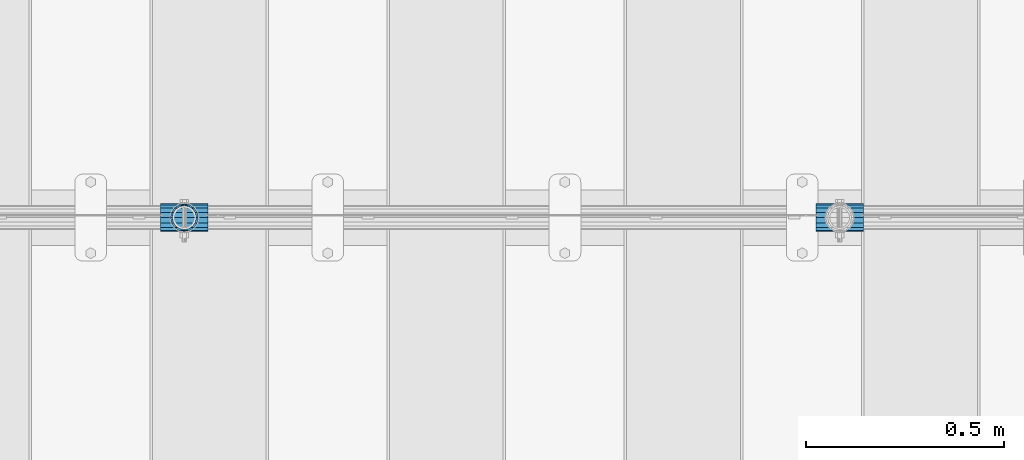
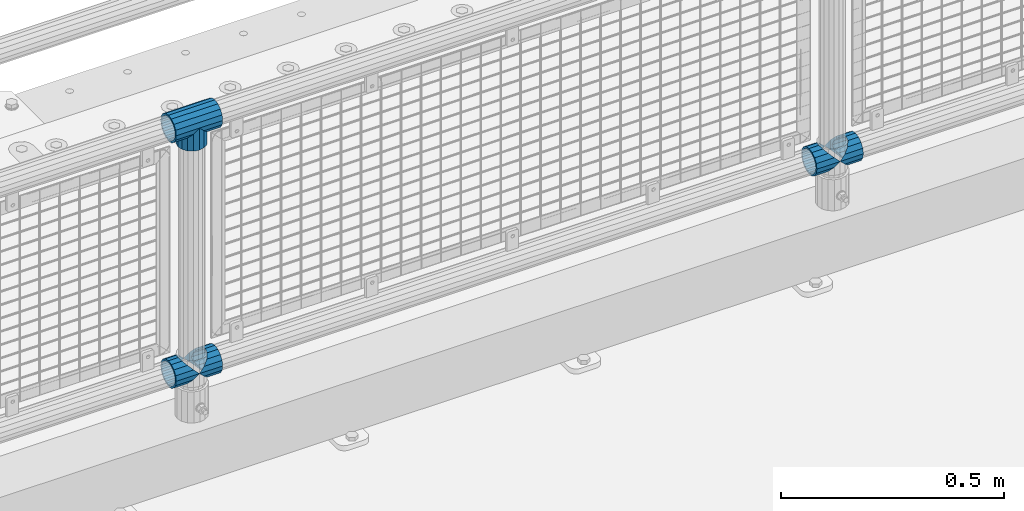
# One storey, part 114 of 193: 6 beams.
"""IFC2X3 building model written with IfcOpenShell, lengths in millimetres."""

from ifc_helpers import new_model, si_unit, frame, origin_with_axes, place, context, subcontext, project, spatial, faceted_brep, material, type_object, element, save


model = new_model("IFC2X3")

# Units and contexts
model_context = context("Model", 3, precision=1e-05, world=origin_with_axes())
body_context = subcontext(model_context, "Body", "Model", "MODEL_VIEW")
ifc_project = project(units=[si_unit("LENGTHUNIT", "METRE", prefix="MILLI"), si_unit("AREAUNIT", "SQUARE_METRE"), si_unit("VOLUMEUNIT", "CUBIC_METRE"), si_unit("MASSUNIT", "GRAM", prefix="KILO"), si_unit("TIMEUNIT", "SECOND"), si_unit("PLANEANGLEUNIT", "RADIAN"), si_unit("SOLIDANGLEUNIT", "STERADIAN"), si_unit("THERMODYNAMICTEMPERATUREUNIT", "DEGREE_CELSIUS"), si_unit("LUMINOUSINTENSITYUNIT", "LUMEN")], contexts=[model_context])

# Site, building, storey
site_placement = place(None, origin_with_axes())
site = spatial("IfcSite", under=ifc_project, at=site_placement, CompositionType="ELEMENT")
building_placement = place(site_placement, origin_with_axes())
building = spatial("IfcBuilding", under=site, at=building_placement, Name="Standard", CompositionType="ELEMENT")
storey_placement = place(building_placement, origin_with_axes())
storey = spatial("IfcBuildingStorey", under=building, at=storey_placement, Name="Undefined", CompositionType="ELEMENT", Elevation=0.0)

# Beams
ifc_material = material(Name="Misc_Undefined")
beam_type = type_object("IfcBeamType", PredefinedType="NOTDEFINED")
beam_1_placement = place(storey_placement, frame((-36915.15, 28664.5, 298.17), z_axis=(0.0, 1.0, 0.0), x_axis=(1.0, 0.0, 0.0)))
element("IfcBeam", 1, at=beam_1_placement, inside=storey, type_object=beam_type, material=ifc_material, context=body_context, shape_type="Brep", body=[
    faceted_brep([(60.1500000000015, 0.0, -35.1500000000015), (46.6986773523677, 13.4513226476329, -32.4743655677703), (46.6986773523677, -13.4513226476329, -32.4743655677703), (33.0273231408864, 21.4606908090117, 21.46069080901), (27.6756344322312, 26.8123795176734, 13.4513226476338), (27.6756344322312, 32.4743655677717, 13.4513226476338), (35.2951966412948, 24.8548033587072, 24.8548033587067), (35.2951966412948, 16.3810424080078, 24.8548033587067), (27.3102561882843, 28.0397438117175, 11.614442172282), (25.0, 30.35, 0.0), (25.0, 35.15, 0.0), (27.6756344322312, 26.8123795176755, -13.4513226476338), (27.6756344322312, 32.4743655677717, -13.4513226476338), (27.3102561882843, 28.0397438117175, -11.614442172282), (35.2951966412948, 16.3810424080013, -24.8548033587067), (35.2951966412948, 24.8548033587072, -24.8548033587067), (33.0273231408974, 21.4606908090117, -21.46069080901), (40.0617968770202, 11.6144421722805, -28.0397438117179), (43.519339601633, 0.0, -30.3499999999985), (40.0617968770202, -11.6144421722805, -28.0397438117179), (35.2951966412948, -16.3810424080013, -24.8548033587067), (35.2951966412948, -24.8548033587072, -24.8548033587067), (33.0273231408974, -21.4606908090117, -21.46069080901), (27.6756344322312, -26.8123795176734, -13.4513226476338), (27.6756344322312, -32.4743655677717, -13.4513226476338), (27.3102561882843, -28.0397438117175, -11.614442172282), (25.0, -30.35, 0.0), (25.0, -35.15, 0.0), (27.3102561882843, -28.0397438117175, 11.614442172282), (27.6756344322312, -26.8123795176755, 13.4513226476338), (27.6756344322312, -32.4743655677717, 13.4513226476338), (33.0273231408864, -21.4606908090117, 21.46069080901), (35.2951966412948, -16.3810424080013, 24.8548033587067), (35.2951966412948, -24.8548033587072, 24.8548033587067), (60.1500000000015, 0.0, 35.1500000000015), (46.6986773523677, -13.4513226476329, 32.4743655677703), (46.6986773523677, 13.4513226476329, 32.4743655677703), (40.0617968770275, -11.6144421722805, 28.0397438117179), (43.5193396016439, 0.0, 30.3499999999985), (40.0617968770275, 11.6144421722805, 28.0397438117179), (0.0, -32.4743655677703, -13.4513226476338), (0.0, -24.8548033587067, -24.8548033587067), (0.0, -13.4513226476338, -32.4743655677703), (0.0, 0.0, -35.1500000000015), (0.0, 13.4513226476338, -32.4743655677703), (0.0, 24.8548033587067, -24.8548033587067), (0.0, 32.4743655677703, -13.4513226476338), (0.0, 35.1500000000015, 0.0), (0.0, 32.4743655677703, 13.4513226476338), (0.0, 24.8548033587067, 24.8548033587067), (0.0, 13.4513226476338, 32.4743655677703), (0.0, 0.0, 35.1500000000015), (0.0, -32.4743655677703, 13.4513226476338), (0.0, -35.1500000000015, 0.0), (0.0, -24.8548033587067, 24.8548033587067), (0.0, -13.4513226476338, 32.4743655677703), (0.0, -28.0397438117179, -11.614442172282), (0.0, -21.46069080901, -21.46069080901), (0.0, -11.614442172282, -28.0397438117179), (0.0, 0.0, -30.3499999999985), (0.0, 11.614442172282, -28.0397438117179), (0.0, 21.46069080901, -21.46069080901), (0.0, 28.0397438117179, -11.614442172282), (0.0, 30.3499999999985, 0.0), (0.0, 28.0397438117179, 11.614442172282), (0.0, 21.46069080901, 21.46069080901), (0.0, 11.614442172282, 28.0397438117179), (0.0, 0.0, 30.3499999999985), (0.0, -11.614442172282, 28.0397438117179), (0.0, -21.46069080901, 21.46069080901), (0.0, -28.0397438117179, 11.614442172282), (0.0, -30.3499999999985, 0.0)], [[[0, 1, 2]], [[3, 4, 5, 6, 7]], [[8, 9, 10, 5, 4]], [[11, 12, 10, 9, 13]], [[14, 15, 12, 11, 16]], [[2, 1, 15, 14, 17, 18, 19, 20, 21]], [[21, 20, 22, 23, 24]], [[24, 23, 25, 26, 27]], [[27, 26, 28, 29, 30]], [[30, 29, 31, 32, 33]], [[34, 35, 36]], [[33, 32, 37, 38, 39, 7, 6, 36, 35]], [[40, 41, 21, 24]], [[41, 42, 2, 21]], [[42, 43, 0, 2]], [[43, 44, 1, 0]], [[44, 45, 15, 1]], [[45, 46, 12, 15]], [[46, 47, 10, 12]], [[47, 48, 5, 10]], [[48, 49, 6, 5]], [[49, 50, 36, 6]], [[50, 51, 34, 36]], [[52, 53, 27, 30]], [[54, 52, 30, 33]], [[55, 54, 33, 35]], [[51, 55, 35, 34]], [[53, 40, 24, 27]], [[52, 54, 55, 51, 50, 49, 48, 47, 46, 45, 44, 43, 42, 41, 40, 53], [56, 57, 58, 59, 60, 61, 62, 63, 64, 65, 66, 67, 68, 69, 70, 71]], [[68, 67, 38, 37]], [[31, 69, 68, 37, 32]], [[28, 70, 69, 31, 29]], [[71, 70, 28, 26]], [[56, 71, 26, 25]], [[57, 56, 25, 23, 22]], [[58, 57, 22, 20, 19]], [[59, 58, 19, 18]], [[60, 59, 18, 17]], [[16, 61, 60, 17, 14]], [[13, 62, 61, 16, 11]], [[63, 62, 13, 9]], [[64, 63, 9, 8]], [[65, 64, 8, 4, 3]], [[66, 65, 3, 7, 39]], [[67, 66, 39, 38]]]),
])
beam_2_placement = place(storey_placement, frame((-36855.0, 28664.5, 298.17), z_axis=(0.0, 1.0, 0.0), x_axis=(1.0, 0.0, 0.0)))
element("IfcBeam", 2, at=beam_2_placement, inside=storey, type_object=beam_type, material=ifc_material, context=body_context, shape_type="Brep", body=[
    faceted_brep([(0.0, 0.0, 35.1500000000015), (13.4513226476338, 13.4513226476329, 32.4743655677703), (13.4513226476338, -13.4513226476329, 32.4743655677703), (24.8548033587067, -16.3810424080013, -24.8548033587067), (24.8548033587067, -24.8548033587072, -24.8548033587067), (32.4743655677703, -32.4743655677717, -13.4513226476338), (32.4743655677703, -26.8123795176754, -13.4513226476338), (27.1226768591114, -21.4606908090117, -21.46069080901), (0.0, 0.0, -35.1500000000015), (13.4513226476338, -13.4513226476329, -32.4743655677703), (13.4513226476338, 13.4513226476329, -32.4743655677703), (20.0882031229849, -11.6144421722805, -28.0397438117179), (16.6306603983721, 0.0, -30.3499999999985), (20.0882031229849, 11.6144421722805, -28.0397438117179), (24.8548033587067, 16.3810424080013, -24.8548033587067), (24.8548033587067, 24.8548033587072, -24.8548033587067), (27.1226768591114, 21.4606908090117, -21.46069080901), (32.4743655677703, 26.8123795176776, -13.4513226476338), (32.4743655677703, 32.4743655677717, -13.4513226476338), (32.8397438117172, 28.0397438117175, -11.614442172282), (35.1500000000015, 30.35, 0.0), (35.1500000000015, 35.15, 0.0), (32.8397438117208, 28.0397438117175, 11.614442172282), (32.4743655677703, 26.8123795176754, 13.4513226476338), (32.4743655677703, 32.4743655677717, 13.4513226476338), (27.1226768591041, 21.4606908090117, 21.46069080901), (24.8548033587067, 16.3810424080078, 24.8548033587067), (24.8548033587067, 24.8548033587072, 24.8548033587067), (20.0882031229849, 11.6144421722805, 28.0397438117179), (16.6306603983685, 0.0, 30.3499999999985), (20.0882031229849, -11.6144421722805, 28.0397438117179), (24.8548033587067, -16.3810424080013, 24.8548033587067), (24.8548033587067, -24.8548033587072, 24.8548033587067), (27.1226768591041, -21.4606908090117, 21.46069080901), (32.4743655677703, -26.8123795176776, 13.4513226476338), (32.4743655677703, -32.4743655677717, 13.4513226476338), (32.8397438117208, -28.0397438117175, 11.614442172282), (35.1500000000015, -30.35, 0.0), (35.1500000000015, -35.15, 0.0), (32.8397438117172, -28.0397438117175, -11.614442172282), (60.1500000000015, -24.8548033587072, -24.8548033587067), (60.1500000000015, -32.4743655677717, -13.4513226476338), (60.1500000000015, -13.4513226476329, -32.4743655677703), (60.1500000000015, 0.0, -35.1500000000015), (60.1500000000015, 13.4513226476329, -32.4743655677703), (60.1500000000015, 24.8548033587072, -24.8548033587067), (60.1500000000015, 32.4743655677717, -13.4513226476338), (60.1500000000015, 35.15, 0.0), (60.1500000000015, 32.4743655677717, 13.4513226476338), (60.1500000000015, 24.8548033587072, 24.8548033587067), (60.1500000000015, 13.4513226476329, 32.4743655677703), (60.1500000000015, 0.0, 35.1500000000015), (60.1500000000015, -13.4513226476329, 32.4743655677703), (60.1500000000015, -24.8548033587072, 24.8548033587067), (60.1500000000015, -32.4743655677717, 13.4513226476338), (60.1500000000015, -35.15, 0.0), (60.1500000000015, -21.4606908090117, 21.46069080901), (60.1500000000015, -11.6144421722805, 28.0397438117179), (60.1500000000015, 0.0, 30.3499999999985), (60.1500000000015, 11.6144421722805, 28.0397438117179), (60.1500000000015, 21.4606908090117, 21.46069080901), (60.1500000000015, 28.0397438117175, 11.614442172282), (60.1500000000015, 30.35, 0.0), (60.1500000000015, 28.0397438117175, -11.614442172282), (60.1500000000015, 21.4606908090117, -21.46069080901), (60.1500000000015, 11.6144421722805, -28.0397438117179), (60.1500000000015, 0.0, -30.3499999999985), (60.1500000000015, -11.6144421722805, -28.0397438117179), (60.1500000000015, -21.4606908090117, -21.46069080901), (60.1500000000015, -28.0397438117175, -11.614442172282), (60.1500000000015, -30.35, 0.0), (60.1500000000015, -28.0397438117175, 11.614442172282)], [[[0, 1, 2]], [[3, 4, 5, 6, 7]], [[8, 9, 10]], [[10, 9, 4, 3, 11, 12, 13, 14, 15]], [[15, 14, 16, 17, 18]], [[18, 17, 19, 20, 21]], [[21, 20, 22, 23, 24]], [[24, 23, 25, 26, 27]], [[27, 26, 28, 29, 30, 31, 32, 2, 1]], [[33, 34, 35, 32, 31]], [[36, 37, 38, 35, 34]], [[6, 5, 38, 37, 39]], [[40, 41, 5, 4]], [[42, 40, 4, 9]], [[43, 42, 9, 8]], [[44, 43, 8, 10]], [[45, 44, 10, 15]], [[46, 45, 15, 18]], [[47, 46, 18, 21]], [[48, 47, 21, 24]], [[49, 48, 24, 27]], [[50, 49, 27, 1]], [[51, 50, 1, 0]], [[52, 51, 0, 2]], [[53, 52, 2, 32]], [[54, 53, 32, 35]], [[55, 54, 35, 38]], [[41, 55, 38, 5]], [[40, 42, 43, 44, 45, 46, 47, 48, 49, 50, 51, 52, 53, 54, 55, 41], [56, 57, 58, 59, 60, 61, 62, 63, 64, 65, 66, 67, 68, 69, 70, 71]], [[71, 70, 37, 36]], [[56, 71, 36, 34, 33]], [[57, 56, 33, 31, 30]], [[58, 57, 30, 29]], [[59, 58, 29, 28]], [[25, 60, 59, 28, 26]], [[22, 61, 60, 25, 23]], [[62, 61, 22, 20]], [[63, 62, 20, 19]], [[64, 63, 19, 17, 16]], [[65, 64, 16, 14, 13]], [[66, 65, 13, 12]], [[67, 66, 12, 11]], [[7, 68, 67, 11, 3]], [[39, 69, 68, 7, 6]], [[70, 69, 39, 37]]]),
])
beam_3_placement = place(storey_placement, frame((-38573.15, 28664.5, 298.17), z_axis=(0.0, 1.0, 0.0), x_axis=(1.0, 0.0, 0.0)))
element("IfcBeam", 3, at=beam_3_placement, inside=storey, type_object=beam_type, material=ifc_material, context=body_context, shape_type="Brep", body=[
    faceted_brep([(60.1500000000015, 0.0, -35.1500000000015), (46.6986773523677, 13.4513226476329, -32.4743655677703), (46.6986773523677, -13.4513226476329, -32.4743655677703), (33.0273231408864, 21.4606908090117, 21.46069080901), (27.6756344322312, 26.8123795176734, 13.4513226476338), (27.6756344322312, 32.4743655677717, 13.4513226476338), (35.2951966412948, 24.8548033587072, 24.8548033587067), (35.2951966412948, 16.3810424080078, 24.8548033587067), (27.3102561882843, 28.0397438117175, 11.614442172282), (25.0, 30.35, 0.0), (25.0, 35.15, 0.0), (27.6756344322312, 26.8123795176755, -13.4513226476338), (27.6756344322312, 32.4743655677717, -13.4513226476338), (27.3102561882843, 28.0397438117175, -11.614442172282), (35.2951966412948, 16.3810424080013, -24.8548033587067), (35.2951966412948, 24.8548033587072, -24.8548033587067), (33.0273231408974, 21.4606908090117, -21.46069080901), (40.0617968770202, 11.6144421722805, -28.0397438117179), (43.519339601633, 0.0, -30.3499999999985), (40.0617968770202, -11.6144421722805, -28.0397438117179), (35.2951966412948, -16.3810424080013, -24.8548033587067), (35.2951966412948, -24.8548033587072, -24.8548033587067), (33.0273231408974, -21.4606908090117, -21.46069080901), (27.6756344322312, -26.8123795176734, -13.4513226476338), (27.6756344322312, -32.4743655677717, -13.4513226476338), (27.3102561882843, -28.0397438117175, -11.614442172282), (25.0, -30.35, 0.0), (25.0, -35.15, 0.0), (27.3102561882843, -28.0397438117175, 11.614442172282), (27.6756344322312, -26.8123795176755, 13.4513226476338), (27.6756344322312, -32.4743655677717, 13.4513226476338), (33.0273231408864, -21.4606908090117, 21.46069080901), (35.2951966412948, -16.3810424080013, 24.8548033587067), (35.2951966412948, -24.8548033587072, 24.8548033587067), (60.1500000000015, 0.0, 35.1500000000015), (46.6986773523677, -13.4513226476329, 32.4743655677703), (46.6986773523677, 13.4513226476329, 32.4743655677703), (40.0617968770275, -11.6144421722805, 28.0397438117179), (43.5193396016439, 0.0, 30.3499999999985), (40.0617968770275, 11.6144421722805, 28.0397438117179), (0.0, -32.4743655677703, -13.4513226476338), (0.0, -24.8548033587067, -24.8548033587067), (0.0, -13.4513226476338, -32.4743655677703), (0.0, 0.0, -35.1500000000015), (0.0, 13.4513226476338, -32.4743655677703), (0.0, 24.8548033587067, -24.8548033587067), (0.0, 32.4743655677703, -13.4513226476338), (0.0, 35.1500000000015, 0.0), (0.0, 32.4743655677703, 13.4513226476338), (0.0, 24.8548033587067, 24.8548033587067), (0.0, 13.4513226476338, 32.4743655677703), (0.0, 0.0, 35.1500000000015), (0.0, -32.4743655677703, 13.4513226476338), (0.0, -35.1500000000015, 0.0), (0.0, -24.8548033587067, 24.8548033587067), (0.0, -13.4513226476338, 32.4743655677703), (0.0, -28.0397438117179, -11.614442172282), (0.0, -21.46069080901, -21.46069080901), (0.0, -11.614442172282, -28.0397438117179), (0.0, 0.0, -30.3499999999985), (0.0, 11.614442172282, -28.0397438117179), (0.0, 21.46069080901, -21.46069080901), (0.0, 28.0397438117179, -11.614442172282), (0.0, 30.3499999999985, 0.0), (0.0, 28.0397438117179, 11.614442172282), (0.0, 21.46069080901, 21.46069080901), (0.0, 11.614442172282, 28.0397438117179), (0.0, 0.0, 30.3499999999985), (0.0, -11.614442172282, 28.0397438117179), (0.0, -21.46069080901, 21.46069080901), (0.0, -28.0397438117179, 11.614442172282), (0.0, -30.3499999999985, 0.0)], [[[0, 1, 2]], [[3, 4, 5, 6, 7]], [[8, 9, 10, 5, 4]], [[11, 12, 10, 9, 13]], [[14, 15, 12, 11, 16]], [[2, 1, 15, 14, 17, 18, 19, 20, 21]], [[21, 20, 22, 23, 24]], [[24, 23, 25, 26, 27]], [[27, 26, 28, 29, 30]], [[30, 29, 31, 32, 33]], [[34, 35, 36]], [[33, 32, 37, 38, 39, 7, 6, 36, 35]], [[40, 41, 21, 24]], [[41, 42, 2, 21]], [[42, 43, 0, 2]], [[43, 44, 1, 0]], [[44, 45, 15, 1]], [[45, 46, 12, 15]], [[46, 47, 10, 12]], [[47, 48, 5, 10]], [[48, 49, 6, 5]], [[49, 50, 36, 6]], [[50, 51, 34, 36]], [[52, 53, 27, 30]], [[54, 52, 30, 33]], [[55, 54, 33, 35]], [[51, 55, 35, 34]], [[53, 40, 24, 27]], [[52, 54, 55, 51, 50, 49, 48, 47, 46, 45, 44, 43, 42, 41, 40, 53], [56, 57, 58, 59, 60, 61, 62, 63, 64, 65, 66, 67, 68, 69, 70, 71]], [[68, 67, 38, 37]], [[31, 69, 68, 37, 32]], [[28, 70, 69, 31, 29]], [[71, 70, 28, 26]], [[56, 71, 26, 25]], [[57, 56, 25, 23, 22]], [[58, 57, 22, 20, 19]], [[59, 58, 19, 18]], [[60, 59, 18, 17]], [[16, 61, 60, 17, 14]], [[13, 62, 61, 16, 11]], [[63, 62, 13, 9]], [[64, 63, 9, 8]], [[65, 64, 8, 4, 3]], [[66, 65, 3, 7, 39]], [[67, 66, 39, 38]]]),
])
beam_4_placement = place(storey_placement, frame((-38513.0, 28664.5, 298.17), z_axis=(0.0, 1.0, 0.0), x_axis=(1.0, 0.0, 0.0)))
element("IfcBeam", 4, at=beam_4_placement, inside=storey, type_object=beam_type, material=ifc_material, context=body_context, shape_type="Brep", body=[
    faceted_brep([(0.0, 0.0, 35.1500000000015), (13.4513226476338, 13.4513226476329, 32.4743655677703), (13.4513226476338, -13.4513226476329, 32.4743655677703), (24.8548033587067, -16.3810424080013, -24.8548033587067), (24.8548033587067, -24.8548033587072, -24.8548033587067), (32.4743655677703, -32.4743655677717, -13.4513226476338), (32.4743655677703, -26.8123795176754, -13.4513226476338), (27.1226768591114, -21.4606908090117, -21.46069080901), (0.0, 0.0, -35.1500000000015), (13.4513226476338, -13.4513226476329, -32.4743655677703), (13.4513226476338, 13.4513226476329, -32.4743655677703), (20.0882031229849, -11.6144421722805, -28.0397438117179), (16.6306603983721, 0.0, -30.3499999999985), (20.0882031229849, 11.6144421722805, -28.0397438117179), (24.8548033587067, 16.3810424080013, -24.8548033587067), (24.8548033587067, 24.8548033587072, -24.8548033587067), (27.1226768591114, 21.4606908090117, -21.46069080901), (32.4743655677703, 26.8123795176776, -13.4513226476338), (32.4743655677703, 32.4743655677717, -13.4513226476338), (32.8397438117172, 28.0397438117175, -11.614442172282), (35.1500000000015, 30.35, 0.0), (35.1500000000015, 35.15, 0.0), (32.8397438117208, 28.0397438117175, 11.614442172282), (32.4743655677703, 26.8123795176754, 13.4513226476338), (32.4743655677703, 32.4743655677717, 13.4513226476338), (27.1226768591041, 21.4606908090117, 21.46069080901), (24.8548033587067, 16.3810424080078, 24.8548033587067), (24.8548033587067, 24.8548033587072, 24.8548033587067), (20.0882031229849, 11.6144421722805, 28.0397438117179), (16.6306603983685, 0.0, 30.3499999999985), (20.0882031229849, -11.6144421722805, 28.0397438117179), (24.8548033587067, -16.3810424080013, 24.8548033587067), (24.8548033587067, -24.8548033587072, 24.8548033587067), (27.1226768591041, -21.4606908090117, 21.46069080901), (32.4743655677703, -26.8123795176776, 13.4513226476338), (32.4743655677703, -32.4743655677717, 13.4513226476338), (32.8397438117208, -28.0397438117175, 11.614442172282), (35.1500000000015, -30.35, 0.0), (35.1500000000015, -35.15, 0.0), (32.8397438117172, -28.0397438117175, -11.614442172282), (60.1500000000015, -24.8548033587072, -24.8548033587067), (60.1500000000015, -32.4743655677717, -13.4513226476338), (60.1500000000015, -13.4513226476329, -32.4743655677703), (60.1500000000015, 0.0, -35.1500000000015), (60.1500000000015, 13.4513226476329, -32.4743655677703), (60.1500000000015, 24.8548033587072, -24.8548033587067), (60.1500000000015, 32.4743655677717, -13.4513226476338), (60.1500000000015, 35.15, 0.0), (60.1500000000015, 32.4743655677717, 13.4513226476338), (60.1500000000015, 24.8548033587072, 24.8548033587067), (60.1500000000015, 13.4513226476329, 32.4743655677703), (60.1500000000015, 0.0, 35.1500000000015), (60.1500000000015, -13.4513226476329, 32.4743655677703), (60.1500000000015, -24.8548033587072, 24.8548033587067), (60.1500000000015, -32.4743655677717, 13.4513226476338), (60.1500000000015, -35.15, 0.0), (60.1500000000015, -21.4606908090117, 21.46069080901), (60.1500000000015, -11.6144421722805, 28.0397438117179), (60.1500000000015, 0.0, 30.3499999999985), (60.1500000000015, 11.6144421722805, 28.0397438117179), (60.1500000000015, 21.4606908090117, 21.46069080901), (60.1500000000015, 28.0397438117175, 11.614442172282), (60.1500000000015, 30.35, 0.0), (60.1500000000015, 28.0397438117175, -11.614442172282), (60.1500000000015, 21.4606908090117, -21.46069080901), (60.1500000000015, 11.6144421722805, -28.0397438117179), (60.1500000000015, 0.0, -30.3499999999985), (60.1500000000015, -11.6144421722805, -28.0397438117179), (60.1500000000015, -21.4606908090117, -21.46069080901), (60.1500000000015, -28.0397438117175, -11.614442172282), (60.1500000000015, -30.35, 0.0), (60.1500000000015, -28.0397438117175, 11.614442172282)], [[[0, 1, 2]], [[3, 4, 5, 6, 7]], [[8, 9, 10]], [[10, 9, 4, 3, 11, 12, 13, 14, 15]], [[15, 14, 16, 17, 18]], [[18, 17, 19, 20, 21]], [[21, 20, 22, 23, 24]], [[24, 23, 25, 26, 27]], [[27, 26, 28, 29, 30, 31, 32, 2, 1]], [[33, 34, 35, 32, 31]], [[36, 37, 38, 35, 34]], [[6, 5, 38, 37, 39]], [[40, 41, 5, 4]], [[42, 40, 4, 9]], [[43, 42, 9, 8]], [[44, 43, 8, 10]], [[45, 44, 10, 15]], [[46, 45, 15, 18]], [[47, 46, 18, 21]], [[48, 47, 21, 24]], [[49, 48, 24, 27]], [[50, 49, 27, 1]], [[51, 50, 1, 0]], [[52, 51, 0, 2]], [[53, 52, 2, 32]], [[54, 53, 32, 35]], [[55, 54, 35, 38]], [[41, 55, 38, 5]], [[40, 42, 43, 44, 45, 46, 47, 48, 49, 50, 51, 52, 53, 54, 55, 41], [56, 57, 58, 59, 60, 61, 62, 63, 64, 65, 66, 67, 68, 69, 70, 71]], [[71, 70, 37, 36]], [[56, 71, 36, 34, 33]], [[57, 56, 33, 31, 30]], [[58, 57, 30, 29]], [[59, 58, 29, 28]], [[25, 60, 59, 28, 26]], [[22, 61, 60, 25, 23]], [[62, 61, 22, 20]], [[63, 62, 20, 19]], [[64, 63, 19, 17, 16]], [[65, 64, 16, 14, 13]], [[66, 65, 13, 12]], [[67, 66, 12, 11]], [[7, 68, 67, 11, 3]], [[39, 69, 68, 7, 6]], [[70, 69, 39, 37]]]),
])
beam_5_placement = place(storey_placement, frame((-38513.0, 28664.5, 969.849999999999), z_axis=(0.0, 1.0, 0.0), x_axis=(0.0, 0.0, -1.0)))
element("IfcBeam", 5, at=beam_5_placement, inside=storey, type_object=beam_type, material=ifc_material, context=body_context, shape_type="Brep", body=[
    faceted_brep([(0.0, 0.0, 35.1500000000015), (13.4513226476338, 13.4513226476329, 32.4743655677703), (13.4513226476338, -13.4513226476329, 32.4743655677703), (24.8548033587067, -16.3810424080013, -24.8548033587067), (24.8548033587067, -24.8548033587072, -24.8548033587067), (32.4743655677703, -32.4743655677717, -13.4513226476338), (32.4743655677703, -26.8123795176754, -13.4513226476338), (27.1226768591114, -21.4606908090117, -21.46069080901), (0.0, 0.0, -35.1500000000015), (13.4513226476338, -13.4513226476329, -32.4743655677703), (13.4513226476338, 13.4513226476329, -32.4743655677703), (20.0882031229849, -11.6144421722805, -28.0397438117179), (16.6306603983721, 0.0, -30.3499999999985), (20.0882031229849, 11.6144421722805, -28.0397438117179), (24.8548033587067, 16.3810424080013, -24.8548033587067), (24.8548033587067, 24.8548033587072, -24.8548033587067), (27.1226768591114, 21.4606908090117, -21.46069080901), (32.4743655677703, 26.8123795176776, -13.4513226476338), (32.4743655677703, 32.4743655677717, -13.4513226476338), (32.8397438117172, 28.0397438117175, -11.614442172282), (35.1500000000015, 30.35, 0.0), (35.1500000000015, 35.15, 0.0), (32.8397438117208, 28.0397438117175, 11.614442172282), (32.4743655677703, 26.8123795176754, 13.4513226476338), (32.4743655677703, 32.4743655677717, 13.4513226476338), (27.1226768591041, 21.4606908090117, 21.46069080901), (24.8548033587067, 16.3810424080078, 24.8548033587067), (24.8548033587067, 24.8548033587072, 24.8548033587067), (20.0882031229849, 11.6144421722805, 28.0397438117179), (16.6306603983685, 0.0, 30.3499999999985), (20.0882031229849, -11.6144421722805, 28.0397438117179), (24.8548033587067, -16.3810424080013, 24.8548033587067), (24.8548033587067, -24.8548033587072, 24.8548033587067), (27.1226768591041, -21.4606908090117, 21.46069080901), (32.4743655677703, -26.8123795176776, 13.4513226476338), (32.4743655677703, -32.4743655677717, 13.4513226476338), (32.8397438117208, -28.0397438117175, 11.614442172282), (35.1500000000015, -30.35, 0.0), (35.1500000000015, -35.15, 0.0), (32.8397438117172, -28.0397438117175, -11.614442172282), (60.1500000000015, -24.8548033587072, -24.8548033587067), (60.1500000000015, -32.4743655677717, -13.4513226476338), (60.1500000000015, -13.4513226476329, -32.4743655677703), (60.1500000000015, 0.0, -35.1500000000015), (60.1500000000015, 13.4513226476329, -32.4743655677703), (60.1500000000015, 24.8548033587072, -24.8548033587067), (60.1500000000015, 32.4743655677717, -13.4513226476338), (60.1500000000015, 35.15, 0.0), (60.1500000000015, 32.4743655677717, 13.4513226476338), (60.1500000000015, 24.8548033587072, 24.8548033587067), (60.1500000000015, 13.4513226476329, 32.4743655677703), (60.1500000000015, 0.0, 35.1500000000015), (60.1500000000015, -13.4513226476329, 32.4743655677703), (60.1500000000015, -24.8548033587072, 24.8548033587067), (60.1500000000015, -32.4743655677717, 13.4513226476338), (60.1500000000015, -35.15, 0.0), (60.1500000000015, -21.4606908090117, 21.46069080901), (60.1500000000015, -11.6144421722805, 28.0397438117179), (60.1500000000015, 0.0, 30.3499999999985), (60.1500000000015, 11.6144421722805, 28.0397438117179), (60.1500000000015, 21.4606908090117, 21.46069080901), (60.1500000000015, 28.0397438117175, 11.614442172282), (60.1500000000015, 30.35, 0.0), (60.1500000000015, 28.0397438117175, -11.614442172282), (60.1500000000015, 21.4606908090117, -21.46069080901), (60.1500000000015, 11.6144421722805, -28.0397438117179), (60.1500000000015, 0.0, -30.3499999999985), (60.1500000000015, -11.6144421722805, -28.0397438117179), (60.1500000000015, -21.4606908090117, -21.46069080901), (60.1500000000015, -28.0397438117175, -11.614442172282), (60.1500000000015, -30.35, 0.0), (60.1500000000015, -28.0397438117175, 11.614442172282)], [[[0, 1, 2]], [[3, 4, 5, 6, 7]], [[8, 9, 10]], [[10, 9, 4, 3, 11, 12, 13, 14, 15]], [[15, 14, 16, 17, 18]], [[18, 17, 19, 20, 21]], [[21, 20, 22, 23, 24]], [[24, 23, 25, 26, 27]], [[27, 26, 28, 29, 30, 31, 32, 2, 1]], [[33, 34, 35, 32, 31]], [[36, 37, 38, 35, 34]], [[6, 5, 38, 37, 39]], [[40, 41, 5, 4]], [[42, 40, 4, 9]], [[43, 42, 9, 8]], [[44, 43, 8, 10]], [[45, 44, 10, 15]], [[46, 45, 15, 18]], [[47, 46, 18, 21]], [[48, 47, 21, 24]], [[49, 48, 24, 27]], [[50, 49, 27, 1]], [[51, 50, 1, 0]], [[52, 51, 0, 2]], [[53, 52, 2, 32]], [[54, 53, 32, 35]], [[55, 54, 35, 38]], [[41, 55, 38, 5]], [[40, 42, 43, 44, 45, 46, 47, 48, 49, 50, 51, 52, 53, 54, 55, 41], [56, 57, 58, 59, 60, 61, 62, 63, 64, 65, 66, 67, 68, 69, 70, 71]], [[71, 70, 37, 36]], [[56, 71, 36, 34, 33]], [[57, 56, 33, 31, 30]], [[58, 57, 30, 29]], [[59, 58, 29, 28]], [[25, 60, 59, 28, 26]], [[22, 61, 60, 25, 23]], [[62, 61, 22, 20]], [[63, 62, 20, 19]], [[64, 63, 19, 17, 16]], [[65, 64, 16, 14, 13]], [[66, 65, 13, 12]], [[67, 66, 12, 11]], [[7, 68, 67, 11, 3]], [[39, 69, 68, 7, 6]], [[70, 69, 39, 37]]]),
])
beam_6_placement = place(storey_placement, frame((-38573.15, 28664.5, 969.849999999999), z_axis=(0.0, 0.0, 1.0), x_axis=(1.0, 0.0, 0.0)))
element("IfcBeam", 6, at=beam_6_placement, inside=storey, type_object=beam_type, material=ifc_material, context=body_context, shape_type="Brep", body=[
    faceted_brep([(88.1897438117194, -11.614442172282, -28.0397438117176), (88.1897438117194, -11.614442172282, -32.8397438117171), (86.9623795176703, -13.4513226476338, -32.4743655677718), (81.6106908090114, -21.46069080901, -27.1226768591079), (81.6106908090114, -21.46069080901, -21.4606908090117), (76.531042407998, -24.8548033587067, -24.8548033587072), (71.7644421722835, -28.0397438117179, -20.0882031229796), (71.7644421722835, -28.0397438117179, -11.6144421722805), (60.1500000000015, -30.3499999999985, -16.6306603983672), (60.1500000000015, -30.35, 0.0), (48.5355578277195, -28.0397438117179, -20.0882031229796), (48.5355578277195, -28.0397438117179, -11.6144421722805), (43.7689575919976, -24.8548033587067, -24.8548033587072), (38.6893091909915, -21.46069080901, -27.1226768591079), (38.6893091909915, -21.46069080901, -21.4606908090117), (33.3376204823326, -13.4513226476338, -32.4743655677718), (32.1102561882835, -11.614442172282, -32.8397438117171), (32.1102561882835, -11.614442172282, -28.0397438117176), (29.8000000000029, 0.0, -35.15), (29.8000000000029, 0.0, -30.35), (32.1102561882835, 11.614442172282, -32.8397438117171), (32.1102561882835, 11.614442172282, -28.0397438117176), (33.3376204823217, 13.4513226476338, -32.4743655677718), (38.6893091909915, 21.46069080901, -27.1226768591082), (38.6893091909915, 21.46069080901, -21.4606908090117), (43.7689575920012, 24.8548033587067, -24.8548033587072), (48.5355578277195, 28.0397438117179, -20.0882031229862), (48.5355578277195, 28.0397438117179, -11.6144421722805), (60.1500000000015, 30.3499999999985, -16.6306603983672), (60.1500000000015, 30.35, 0.0), (71.7644421722835, 28.0397438117179, -20.0882031229862), (71.7644421722835, 28.0397438117179, -11.6144421722805), (76.5310424080017, 24.8548033587067, -24.8548033587072), (81.6106908090114, 21.46069080901, -27.1226768591082), (81.6106908090114, 21.46069080901, -21.4606908090117), (86.962379517674, 13.4513226476338, -32.4743655677718), (88.1897438117194, 11.614442172282, -32.8397438117171), (88.1897438117194, 11.614442172282, -28.0397438117176), (90.5, 0.0, -35.15), (90.5, 0.0, -30.35), (0.0, -21.46069080901, -21.46069080901), (0.0, -28.0397438117179, -11.614442172282), (0.0, -11.614442172282, -28.0397438117179), (0.0, 0.0, -30.3499999999985), (0.0, 11.614442172282, -28.0397438117179), (0.0, 21.46069080901, -21.46069080901), (0.0, 28.0397438117179, -11.614442172282), (0.0, 30.3499999999985, 0.0), (0.0, 32.4743655677703, -13.4513226476338), (0.0, 35.1500000000015, 0.0), (120.299999999999, 35.1500000000015, 0.0), (120.299999999999, 32.4743655677703, -13.4513226476329), (0.0, 32.4743655677703, 13.4513226476338), (120.299999999999, 32.4743655677703, 13.4513226476329), (0.0, 24.8548033587067, 24.8548033587067), (120.299999999999, 24.8548033587067, 24.8548033587072), (0.0, 13.4513226476338, 32.4743655677703), (120.299999999999, 13.4513226476338, 32.4743655677718), (0.0, 0.0, 35.1500000000015), (120.299999999999, 0.0, 35.15), (0.0, -13.4513226476338, 32.4743655677703), (120.299999999999, -13.4513226476338, 32.4743655677718), (0.0, -24.8548033587067, 24.8548033587067), (120.299999999999, -24.8548033587067, 24.8548033587072), (0.0, -32.4743655677703, 13.4513226476338), (120.299999999999, -32.4743655677703, 13.4513226476329), (0.0, -35.1500000000015, 0.0), (120.299999999999, -35.1500000000015, 0.0), (0.0, -32.4743655677703, -13.4513226476338), (120.299999999999, -32.4743655677703, -13.4513226476329), (0.0, 24.8548033587067, -24.8548033587067), (0.0, 13.4513226476338, -32.4743655677703), (0.0, 0.0, -35.1500000000015), (0.0, -13.4513226476338, -32.4743655677703), (0.0, -24.8548033587067, -24.8548033587067), (0.0, 28.0397438117179, 11.614442172282), (0.0, 21.46069080901, 21.46069080901), (0.0, 11.614442172282, 28.0397438117179), (0.0, 0.0, 30.3499999999985), (0.0, -11.614442172282, 28.0397438117179), (0.0, -21.46069080901, 21.46069080901), (0.0, -28.0397438117179, 11.614442172282), (0.0, -30.3499999999985, 0.0), (120.299999999999, -30.3499999999985, 0.0), (120.299999999999, -28.0397438117179, -11.6144421722805), (120.299999999999, -21.46069080901, -21.4606908090117), (120.299999999999, -11.614442172282, -28.0397438117176), (120.299999999999, 0.0, -30.35), (120.299999999999, 21.46069080901, -21.4606908090117), (120.299999999999, 28.0397438117179, -11.6144421722805), (120.299999999999, 11.614442172282, -28.0397438117176), (120.299999999999, 30.3499999999985, 0.0), (120.299999999999, 28.0397438117179, 11.6144421722805), (120.299999999999, 21.46069080901, 21.4606908090117), (120.299999999999, 11.614442172282, 28.0397438117176), (120.299999999999, 0.0, 30.35), (120.299999999999, -11.614442172282, 28.0397438117176), (120.299999999999, -21.46069080901, 21.4606908090117), (120.299999999999, -28.0397438117179, 11.6144421722805), (120.299999999999, -24.8548033587067, -24.8548033587072), (120.299999999999, -13.4513226476338, -32.4743655677718), (120.299999999999, 0.0, -35.15), (120.299999999999, 13.4513226476338, -32.4743655677718), (120.299999999999, 24.8548033587067, -24.8548033587072)], [[[0, 1, 2, 3, 4]], [[4, 3, 5, 6, 7]], [[7, 6, 8, 9]], [[9, 8, 10, 11]], [[11, 10, 12, 13, 14]], [[14, 13, 15, 16, 17]], [[17, 16, 18, 19]], [[19, 18, 20, 21]], [[21, 20, 22, 23, 24]], [[24, 23, 25, 26, 27]], [[27, 26, 28, 29]], [[29, 28, 30, 31]], [[31, 30, 32, 33, 34]], [[34, 33, 35, 36, 37]], [[37, 36, 38, 39]], [[39, 38, 1, 0]], [[40, 41, 11, 14]], [[42, 40, 14, 17]], [[43, 42, 17, 19]], [[44, 43, 19, 21]], [[45, 44, 21, 24]], [[46, 45, 24, 27]], [[47, 46, 27, 29]], [[48, 49, 50, 51]], [[49, 52, 53, 50]], [[52, 54, 55, 53]], [[54, 56, 57, 55]], [[56, 58, 59, 57]], [[58, 60, 61, 59]], [[60, 62, 63, 61]], [[62, 64, 65, 63]], [[64, 66, 67, 65]], [[66, 68, 69, 67]], [[64, 62, 60, 58, 56, 54, 52, 49, 48, 70, 71, 72, 73, 74, 68, 66], [41, 40, 42, 43, 44, 45, 46, 47, 75, 76, 77, 78, 79, 80, 81, 82]], [[41, 82, 9, 11]], [[83, 84, 7, 9]], [[84, 85, 4, 7]], [[85, 86, 0, 4]], [[86, 87, 39, 0]], [[88, 89, 31, 34]], [[90, 88, 34, 37]], [[87, 90, 37, 39]], [[89, 91, 29, 31]], [[75, 47, 29, 91, 92]], [[76, 75, 92, 93]], [[77, 76, 93, 94]], [[78, 77, 94, 95]], [[79, 78, 95, 96]], [[80, 79, 96, 97]], [[81, 80, 97, 98]], [[9, 82, 81, 98, 83]], [[99, 100, 101, 102, 103, 51, 50, 53, 55, 57, 59, 61, 63, 65, 67, 69], [97, 96, 95, 94, 93, 92, 91, 89, 88, 90, 87, 86, 85, 84, 83, 98]], [[35, 102, 101, 38, 36]], [[32, 103, 102, 35, 33]], [[28, 26, 25, 70, 48, 51, 103, 32, 30]], [[22, 71, 70, 25, 23]], [[18, 72, 71, 22, 20]], [[73, 72, 18, 16, 15]], [[74, 73, 15, 13, 12]], [[99, 69, 68, 74, 12, 10, 8, 6, 5]], [[100, 99, 5, 3, 2]], [[101, 100, 2, 1, 38]]]),
])

save(model, "model.ifc")
